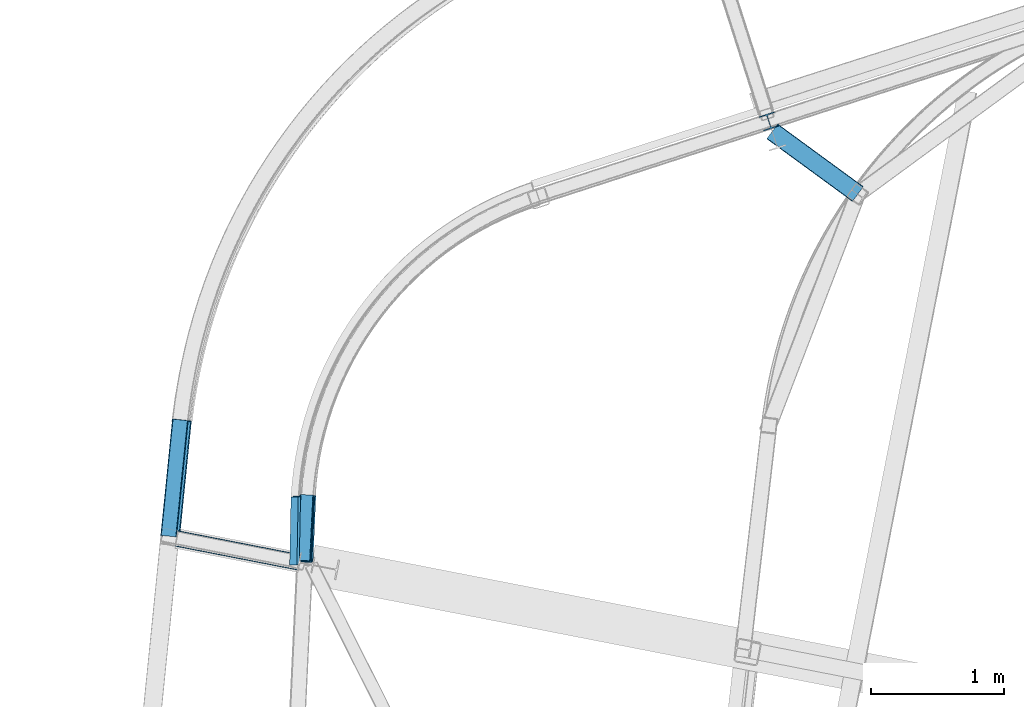
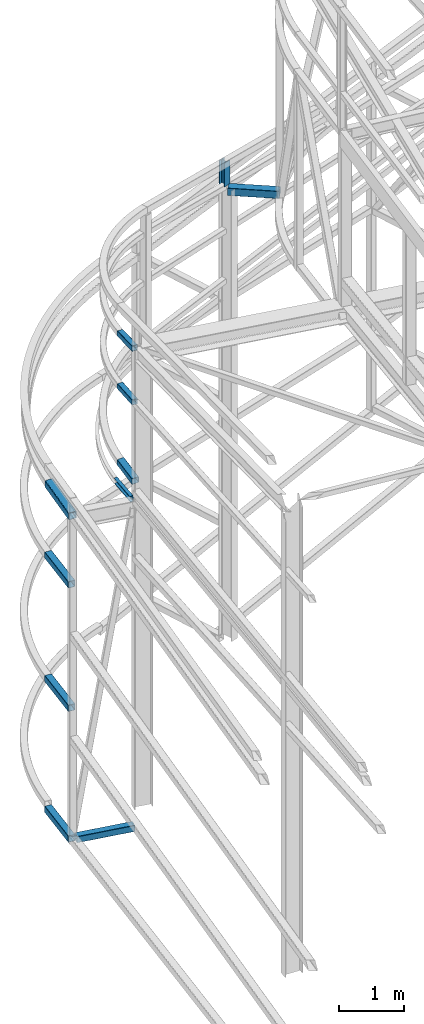
# One storey, part 145 of 215: 11 beams, 11 elements without a shape of their own.
"""IFC2X3 building model written with IfcOpenShell, lengths in millimetres."""

from ifc_helpers import new_model, si_unit, frame, origin_with_axes, origin_2d_with_axis, place, context, subcontext, project, spatial, hollow_rectangle, i_section, u_section, extrude, material, type_object, element, aggregate, save


model = new_model("IFC2X3")

# Units and contexts
model_context = context("Model", 3, precision=1e-05, world=origin_with_axes())
body_context = subcontext(model_context, "Body", "Model", "MODEL_VIEW")
ifc_project = project(units=[si_unit("LENGTHUNIT", "METRE", prefix="MILLI"), si_unit("AREAUNIT", "SQUARE_METRE"), si_unit("VOLUMEUNIT", "CUBIC_METRE"), si_unit("MASSUNIT", "GRAM", prefix="KILO"), si_unit("TIMEUNIT", "SECOND"), si_unit("PLANEANGLEUNIT", "RADIAN"), si_unit("SOLIDANGLEUNIT", "STERADIAN"), si_unit("THERMODYNAMICTEMPERATUREUNIT", "DEGREE_CELSIUS"), si_unit("LUMINOUSINTENSITYUNIT", "LUMEN")], contexts=[model_context])

# Site, building, storey
site_placement = place(None, origin_with_axes())
site = spatial("IfcSite", under=ifc_project, at=site_placement, CompositionType="ELEMENT")
building_placement = place(site_placement, origin_with_axes())
building = spatial("IfcBuilding", under=site, at=building_placement, Name="Undefined", CompositionType="ELEMENT")
storey_placement = place(building_placement, origin_with_axes())
storey = spatial("IfcBuildingStorey", under=building, at=storey_placement, Name="Undefined", CompositionType="ELEMENT", Elevation=0.0)

# Assembly, beam
assembly_1_placement = place(storey_placement, origin_with_axes())
assembly_1 = element("IfcElementAssembly", 1, at=assembly_1_placement, inside=storey, Name="Steel Assembly", AssemblyPlace="NOTDEFINED", PredefinedType="RIGID_FRAME")
ifc_material_1 = material(Name="STEEL/S235JR")
beam_type_1 = type_object("IfcBeamType", PredefinedType="NOTDEFINED")
beam_1_placement = place(assembly_1_placement, frame((39043.4027065131, 54386.6872162552, 6098.34980159661), z_axis=(0.995204652867903, -0.0527159339930026, 0.0823937449890638), x_axis=(0.0426994090116855, 0.991984582271618, 0.118925813032563)))
beam_1 = element("IfcBeam", 2, at=beam_1_placement, type_object=beam_type_1, material=ifc_material_1, Name="LISSE", context=body_context, shape_type="SweptSolid", body=[
    extrude(hollow_rectangle(XDim=120.0, YDim=120.0, WallThickness=5.0, InnerFilletRadius=5.0, OuterFilletRadius=10.0, at=origin_2d_with_axis()), frame((493.486849487216, -1.36424205265939e-12, 7.27681367740632e-12), z_axis=(-1.0, 0.0, 0.0), x_axis=(-6.93889390390723e-18, -1.0, -3.46944695195361e-18)), (0.0, 0.0, 1.0), 493.5),
])
aggregate(assembly_1, [beam_1])

assembly_2_placement = place(storey_placement, origin_with_axes())
assembly_2 = element("IfcElementAssembly", 3, at=assembly_2_placement, inside=storey, Name="Steel Assembly", AssemblyPlace="NOTDEFINED", PredefinedType="RIGID_FRAME")
ifc_material_2 = material(Name="STEEL/S275JR")
beam_2_placement = place(assembly_2_placement, frame((38023.4715261959, 54575.1438884609, 4401.40044525062), z_axis=(-0.994982523266307, 0.10004888002678, 0.0), x_axis=(0.100048880026774, 0.994982523266308, 0.0)))
beam_2 = element("IfcBeam", 4, at=beam_2_placement, type_object=beam_type_1, material=ifc_material_2, Name="LISSE", context=body_context, shape_type="SweptSolid", body=[
    extrude(hollow_rectangle(XDim=120.0, YDim=120.0, WallThickness=5.0, InnerFilletRadius=5.0, OuterFilletRadius=10.0, at=origin_2d_with_axis()), frame((876.402761412209, 9.09494701772928e-13, 0.0), z_axis=(-1.0, 0.0, 0.0), x_axis=(-6.93889390390723e-18, -1.0, -3.46944695195361e-18)), (0.0, 0.0, 1.0), 876.4),
])
aggregate(assembly_2, [beam_2])

assembly_3_placement = place(storey_placement, origin_with_axes())
assembly_3 = element("IfcElementAssembly", 5, at=assembly_3_placement, inside=storey, Name="Steel Assembly", AssemblyPlace="NOTDEFINED", PredefinedType="RIGID_FRAME")
beam_3_placement = place(assembly_3_placement, frame((38023.4715261336, 54575.1438885156, 2088.87296214068), z_axis=(-0.994982523266307, 0.10004888002678, 0.0), x_axis=(0.100048880026774, 0.994982523266308, 0.0)))
beam_3 = element("IfcBeam", 6, at=beam_3_placement, type_object=beam_type_1, material=ifc_material_2, Name="LISSE", context=body_context, shape_type="SweptSolid", body=[
    extrude(hollow_rectangle(XDim=120.0, YDim=120.0, WallThickness=5.0, InnerFilletRadius=5.0, OuterFilletRadius=10.0, at=origin_2d_with_axis()), frame((876.402761412209, 9.09494701772928e-13, 0.0), z_axis=(-1.0, 0.0, 0.0), x_axis=(-6.93889390390723e-18, -1.0, -3.46944695195361e-18)), (0.0, 0.0, 1.0), 876.4),
])
aggregate(assembly_3, [beam_3])

assembly_4_placement = place(storey_placement, origin_with_axes())
assembly_4 = element("IfcElementAssembly", 7, at=assembly_4_placement, inside=storey, Name="Steel Assembly", AssemblyPlace="NOTDEFINED", PredefinedType="RIGID_FRAME")
beam_4_placement = place(assembly_4_placement, frame((38023.4715259585, 54575.1438884777, -359.605096071567), z_axis=(-0.994982523266307, 0.10004888002678, 0.0), x_axis=(0.100048880026774, 0.994982523266308, 0.0)))
beam_4 = element("IfcBeam", 8, at=beam_4_placement, type_object=beam_type_1, material=ifc_material_2, Name="LISSE", context=body_context, shape_type="SweptSolid", body=[
    extrude(hollow_rectangle(XDim=120.0, YDim=120.0, WallThickness=5.0, InnerFilletRadius=5.0, OuterFilletRadius=10.0, at=origin_2d_with_axis()), frame((876.402761412209, 9.09494701772928e-13, 0.0), z_axis=(-1.0, 0.0, 0.0), x_axis=(-6.93889390390723e-18, -1.0, -3.46944695195361e-18)), (0.0, 0.0, 1.0), 876.4),
])
aggregate(assembly_4, [beam_4])

assembly_5_placement = place(storey_placement, origin_with_axes())
assembly_5 = element("IfcElementAssembly", 9, at=assembly_5_placement, inside=storey, Name="Steel Assembly", AssemblyPlace="NOTDEFINED", PredefinedType="RIGID_FRAME")
beam_5_placement = place(assembly_5_placement, frame((38087.0164790327, 54557.0868628991, -359.608691096057), z_axis=(0.0, 0.0, 1.0), x_axis=(0.981473781754569, -0.191596491952085, 1.95999999956393e-07)))
beam_5 = element("IfcBeam", 10, at=beam_5_placement, type_object=beam_type_1, material=ifc_material_2, Name="POUTRE", context=body_context, shape_type="SweptSolid", body=[
    extrude(hollow_rectangle(XDim=120.0, YDim=120.0, WallThickness=5.0, InnerFilletRadius=5.0, OuterFilletRadius=10.0, at=origin_2d_with_axis()), frame((936.796148569767, -1.45674571524284e-11, -2.479678758436e-20), z_axis=(-1.0, 0.0, 0.0), x_axis=(-6.93889390390723e-18, -1.0, -3.46944695195361e-18)), (0.0, 0.0, 1.0), 936.8),
])
aggregate(assembly_5, [beam_5])

assembly_6_placement = place(storey_placement, origin_with_axes())
assembly_6 = element("IfcElementAssembly", 11, at=assembly_6_placement, inside=storey, Name="Steel Assembly", AssemblyPlace="NOTDEFINED", PredefinedType="RIGID_FRAME")
beam_type_2 = type_object("IfcBeamType", PredefinedType="NOTDEFINED")
beam_6_placement = place(assembly_6_placement, frame((39034.5033216486, 54388.5880225305, 8583.57398689803), z_axis=(0.998406509531978, -0.04853772797725, -0.0287842089865063), x_axis=(0.0473209139762036, 0.998015332498212, -0.0415466869791114)))
beam_6 = element("IfcBeam", 12, at=beam_6_placement, type_object=beam_type_2, material=ifc_material_1, Name="LISSE", context=body_context, shape_type="SweptSolid", body=[
    extrude(hollow_rectangle(XDim=100.0, YDim=100.0, WallThickness=5.0, InnerFilletRadius=5.0, OuterFilletRadius=10.0, at=origin_2d_with_axis()), frame((493.486849487216, -1.36424205265939e-12, 7.27681367740632e-12), z_axis=(-1.0, 0.0, 0.0), x_axis=(-6.93889390390723e-18, -1.0, -3.46944695195361e-18)), (0.0, 0.0, 1.0), 493.5),
])
aggregate(assembly_6, [beam_6])

assembly_7_placement = place(storey_placement, origin_with_axes())
assembly_7 = element("IfcElementAssembly", 13, at=assembly_7_placement, inside=storey, Name="Steel Assembly", AssemblyPlace="NOTDEFINED", PredefinedType="RIGID_FRAME")
beam_7_placement = place(assembly_7_placement, frame((39037.1705549335, 54392.0685808841, 7572.88402864382), z_axis=(0.998849258489004, -0.0479599709754609, 0.0), x_axis=(0.0479599709754666, 0.998849258489004, 0.0)))
beam_7 = element("IfcBeam", 14, at=beam_7_placement, type_object=beam_type_2, material=ifc_material_1, Name="LISSE", context=body_context, shape_type="SweptSolid", body=[
    extrude(hollow_rectangle(XDim=100.0, YDim=100.0, WallThickness=5.0, InnerFilletRadius=5.0, OuterFilletRadius=10.0, at=origin_2d_with_axis()), frame((493.486849487216, -1.36424205265939e-12, 7.27681367740632e-12), z_axis=(-1.0, 0.0, 0.0), x_axis=(-6.93889390390723e-18, -1.0, -3.46944695195361e-18)), (0.0, 0.0, 1.0), 493.5),
])
aggregate(assembly_7, [beam_7])

assembly_8_placement = place(storey_placement, origin_with_axes())
assembly_8 = element("IfcElementAssembly", 15, at=assembly_8_placement, inside=storey, Name="Steel Assembly", AssemblyPlace="NOTDEFINED", PredefinedType="RIGID_FRAME")
beam_type_3 = type_object("IfcBeamType", PredefinedType="NOTDEFINED")
beam_8_placement = place(assembly_8_placement, frame((38036.0542364952, 54570.5734759623, 5686.62292738264), z_axis=(-0.993730039130471, 0.102974828013518, -0.0435522000057182), x_axis=(0.100507788985881, 0.99338811086042, 0.0554819389922041)))
beam_8 = element("IfcBeam", 16, at=beam_8_placement, type_object=beam_type_3, material=ifc_material_2, Name="LISSE", context=body_context, shape_type="SweptSolid", body=[
    extrude(hollow_rectangle(XDim=140.0, YDim=140.0, WallThickness=8.0, InnerFilletRadius=12.0, OuterFilletRadius=20.0, at=origin_2d_with_axis()), frame((878.565842630596, -2.21277400273622e-13, 1.56217051221271e-14), z_axis=(-1.0, 0.0, 0.0), x_axis=(-6.93889390390723e-18, -1.0, -3.46944695195361e-18)), (0.0, 0.0, 1.0), 878.6),
])
aggregate(assembly_8, [beam_8])

assembly_9_placement = place(storey_placement, origin_with_axes())
assembly_9 = element("IfcElementAssembly", 17, at=assembly_9_placement, inside=storey, Name="Steel Assembly", AssemblyPlace="NOTDEFINED", PredefinedType="RIGID_FRAME")
beam_type_4 = type_object("IfcBeamType", Name="HEA120", PredefinedType="NOTDEFINED")
beam_9_placement = place(assembly_9_placement, frame((42523.9973282401, 57683.8919665453, 8882.03291048629), z_axis=(0.308275434998926, -0.951297143996671, -1.00000033853226e-09), x_axis=(0.0, 0.0, -1.0)))
beam_9 = element("IfcBeam", 18, at=beam_9_placement, type_object=beam_type_4, material=ifc_material_2, ObjectType="HEA120", context=body_context, shape_type="SweptSolid", body=[
    extrude(i_section(OverallWidth=120.0, OverallDepth=114.0, WebThickness=5.0, FlangeThickness=8.0, FilletRadius=12.0, at=origin_2d_with_axis()), frame((444.263712753138, 0.0, -7.27595761418343e-12), z_axis=(-1.0, 0.0, 0.0), x_axis=(-6.93889390390723e-18, -1.0, -3.46944695195361e-18)), (0.0, 0.0, 1.0), 444.3),
])
aggregate(assembly_9, [beam_9])

assembly_10_placement = place(storey_placement, origin_with_axes())
assembly_10 = element("IfcElementAssembly", 19, at=assembly_10_placement, inside=storey, Name="Steel Assembly", AssemblyPlace="NOTDEFINED", PredefinedType="RIGID_FRAME")
beam_type_5 = type_object("IfcBeamType", Name="UPN120", PredefinedType="NOTDEFINED")
beam_10_placement = place(assembly_10_placement, frame((38967.2345650814, 54363.464821319, 5797.82577328812), z_axis=(0.145554480066031, 0.0676436620306896, -0.987035069447781), x_axis=(0.0195734339973165, 0.997267754863391, 0.0712313539902432)))
beam_10 = element("IfcBeam", 20, at=beam_10_placement, type_object=beam_type_5, material=ifc_material_1, Name="LISSE", ObjectType="UPN120", context=body_context, shape_type="SweptSolid", body=[
    extrude(u_section(Depth=120.0, FlangeWidth=55.0, WebThickness=7.0, FlangeThickness=9.0, FilletRadius=9.0, EdgeRadius=4.5, FlangeSlope=0.0798299857122373, at=origin_2d_with_axis()), frame((509.390052904375, 0.0, 9.16563908838547e-13), z_axis=(-1.0, 0.0, 0.0), x_axis=(-6.93889390390723e-18, -1.0, -3.46944695195361e-18)), (0.0, 0.0, 1.0), 509.4),
])
aggregate(assembly_10, [beam_10])

assembly_11_placement = place(storey_placement, origin_with_axes())
assembly_11 = element("IfcElementAssembly", 21, at=assembly_11_placement, inside=storey, Name="Steel Assembly", AssemblyPlace="NOTDEFINED", PredefinedType="RIGID_FRAME")
beam_type_6 = type_object("IfcBeamType", PredefinedType="NOTDEFINED")
beam_11_placement = place(assembly_11_placement, frame((43190.9649164364, 57139.5279684258, 8373.25645752335), z_axis=(-0.000905759000423403, -0.0012347740005725, -0.999998827466213), x_axis=(-0.807190639024041, 0.590290837017584, 2.24499999911379e-06)))
beam_11 = element("IfcBeam", 22, at=beam_11_placement, type_object=beam_type_6, material=ifc_material_2, context=body_context, shape_type="SweptSolid", body=[
    extrude(hollow_rectangle(XDim=140.0, YDim=140.0, WallThickness=4.0, InnerFilletRadius=4.0, OuterFilletRadius=8.0, at=origin_2d_with_axis()), frame((795.881088211942, -4.63774028087885e-14, 6.90990941407421e-17), z_axis=(-1.0, 0.0, 0.0), x_axis=(-6.93889390390723e-18, -1.0, -3.46944695195361e-18)), (0.0, 0.0, 1.0), 795.9),
])
aggregate(assembly_11, [beam_11])

save(model, "model.ifc")
